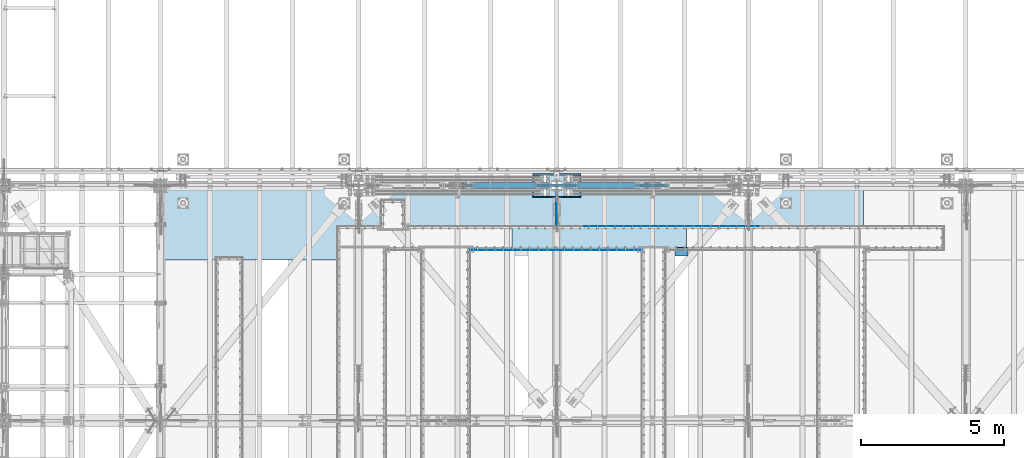
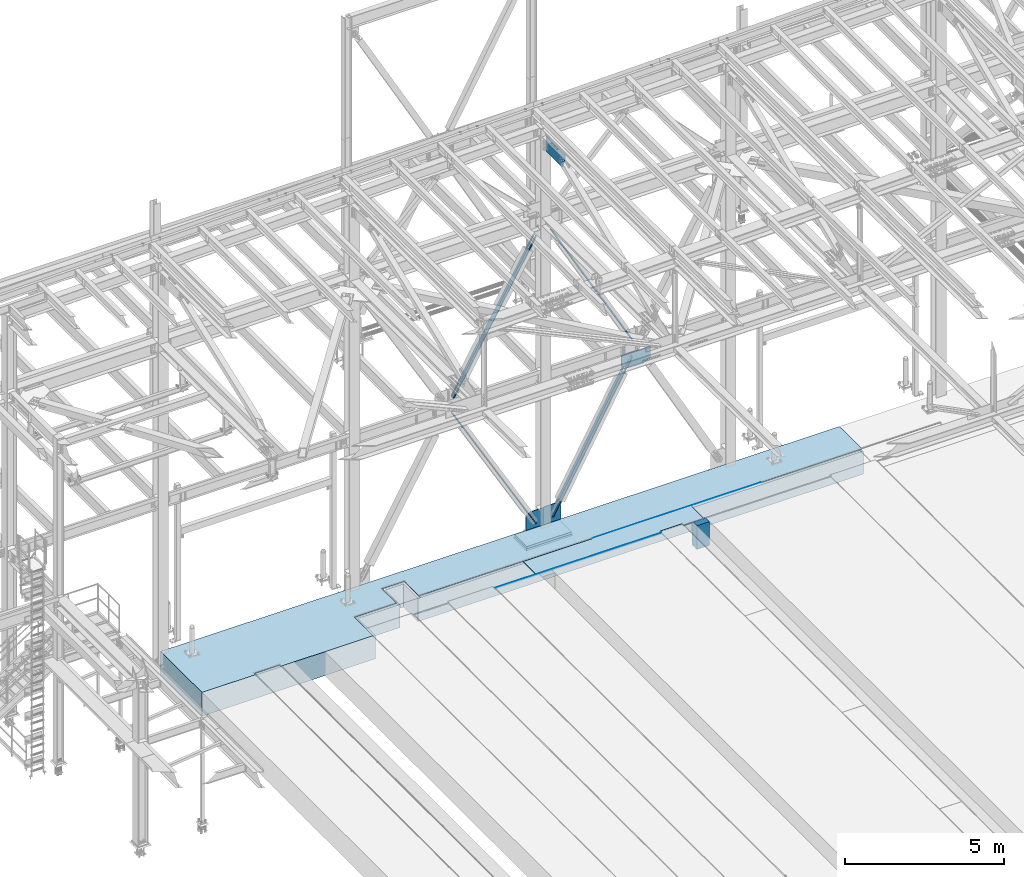
# One storey, part 2992 of 3843: 13 plates, 2 slabs, 13 elements without a shape of their own.
"""IFC2X3 building model written with IfcOpenShell, lengths in millimetres."""

from ifc_helpers import new_model, si_unit, frame, origin_with_axes, place, context, subcontext, project, spatial, faceted_brep, material, type_object, element, aggregate, save


model = new_model("IFC2X3")

# Units and contexts
model_context = context("Model", 3, precision=1e-05, world=origin_with_axes())
body_context = subcontext(model_context, "Body", "Model", "MODEL_VIEW")
ifc_project = project(units=[si_unit("LENGTHUNIT", "METRE", prefix="MILLI"), si_unit("AREAUNIT", "SQUARE_METRE"), si_unit("VOLUMEUNIT", "CUBIC_METRE"), si_unit("MASSUNIT", "GRAM", prefix="KILO"), si_unit("TIMEUNIT", "SECOND"), si_unit("PLANEANGLEUNIT", "RADIAN"), si_unit("SOLIDANGLEUNIT", "STERADIAN"), si_unit("THERMODYNAMICTEMPERATUREUNIT", "DEGREE_CELSIUS"), si_unit("LUMINOUSINTENSITYUNIT", "LUMEN")], contexts=[model_context])

# Site, building, storey
site_placement = place(None, origin_with_axes())
site = spatial("IfcSite", under=ifc_project, at=site_placement, CompositionType="ELEMENT")
building_placement = place(site_placement, origin_with_axes())
building = spatial("IfcBuilding", under=site, at=building_placement, Name="Undefined", CompositionType="ELEMENT")
storey_placement = place(building_placement, origin_with_axes())
storey = spatial("IfcBuildingStorey", under=building, at=storey_placement, Name="Undefined", CompositionType="ELEMENT", Elevation=0.0)

# Assembly, plate
assembly_1_placement = place(storey_placement, origin_with_axes())
assembly_1 = element("IfcElementAssembly", 1, at=assembly_1_placement, inside=storey, Name="EMBED_ANGLE", AssemblyPlace="NOTDEFINED", PredefinedType="RIGID_FRAME")
ifc_material_1 = material(Name="STEEL/A36")
plate_type_1 = type_object("IfcPlateType", PredefinedType="NOTDEFINED")
plate_1_placement = place(assembly_1_placement, frame((52883.562, 89966.6723125, 30480.0000003815), z_axis=(1.0, 0.0, 0.0), x_axis=(0.0, 0.0, -1.0)))
plate_1 = element("IfcPlate", 2, at=plate_1_placement, type_object=plate_type_1, material=ifc_material_1, Name="PLATE", context=body_context, shape_type="Brep", body=[
    faceted_brep([(0.0, -6.34999999999854, 12.6999998092651), (7.27595761418343e-12, 6.3499999046162, 0.0), (25.3999999999942, 6.34999999994034, 2.91038304567337e-11), (25.3999996185303, -1.58750000000873, 7.93749999998545), (20.6374996185259, -6.34999999993306, 12.7000361935643), (25.3999996185303, 6.35000000000582, 6032.56336035329), (25.3999996185194, -1.58750000000873, 6024.56327201604), (20.6374996185186, -6.35000000000582, 6019.80082138476), (3.80663550458848e-07, -6.35000000000582, 6019.80082138476), (3.81471181754023e-07, 6.35000000000582, 6032.56336035157)], [[[0, 1, 2, 3, 4]], [[3, 2, 5, 6]], [[4, 3, 6, 7]], [[0, 4, 7, 8]], [[1, 0, 8, 9]], [[2, 1, 9, 5]], [[8, 7, 6, 5, 9]]]),
])
aggregate(assembly_1, [plate_1])

assembly_2_placement = place(storey_placement, origin_with_axes())
assembly_2 = element("IfcElementAssembly", 3, at=assembly_2_placement, inside=storey, Name="EMBED_ANGLE", AssemblyPlace="NOTDEFINED", PredefinedType="RIGID_FRAME")
plate_2_placement = place(assembly_2_placement, frame((56903.1117470957, 90792.1730468558, 30480.0000003815), z_axis=(1.0, 0.0, 0.0), x_axis=(0.0, 0.0, -1.0)))
plate_2 = element("IfcPlate", 4, at=plate_2_placement, type_object=plate_type_1, material=ifc_material_1, Name="PLATE", context=body_context, shape_type="Brep", body=[
    faceted_brep([(25.3999986084054, 1.58750333315402, 6095.99959179856), (25.3999996185921, 1.58750000000146, 7.27595761418343e-11), (20.6374996185295, 6.35000000000218, -7.27595761418343e-12), (20.6374984169197, 6.35000001081789, 6095.99959179822), (0.0, -6.3499999046162, 0.0), (3.81471181754023e-07, -6.3499999891792, 6095.99959179686), (3.81471181754023e-07, 6.35000001081789, 6095.99959179683), (7.27595761418343e-12, 6.3499999046162, 0.0), (25.3999996185303, -6.34999999999491, 2.91038304567337e-11), (25.3999996185303, -6.3499999891792, 6095.99959179857)], [[[0, 1, 2, 3]], [[4, 5, 6, 7]], [[8, 9, 5, 4]], [[6, 5, 9, 0, 3]], [[7, 6, 3, 2]], [[8, 4, 7, 2, 1]], [[9, 8, 1, 0]]]),
])
aggregate(assembly_2, [plate_2])

assembly_3_placement = place(storey_placement, origin_with_axes())
assembly_3 = element("IfcElementAssembly", 5, at=assembly_3_placement, inside=storey, Name="PLATE", AssemblyPlace="NOTDEFINED", PredefinedType="RIGID_FRAME")
ifc_material_2 = material(Name="STEEL/A572-50")
plate_type_2 = type_object("IfcPlateType", PredefinedType="NOTDEFINED")
plate_3_placement = place(assembly_3_placement, frame((54372.6366220082, 90779.4730010014, 30467.3), z_axis=(1.0, 0.0, 0.0), x_axis=(0.0, -1.0, 0.0)))
plate_3 = element("IfcPlate", 6, at=plate_3_placement, type_object=plate_type_2, material=ifc_material_2, Name="PLATE", context=body_context, shape_type="Brep", body=[
    faceted_brep([(800.099781912155, -12.7000000000007, 4546.63359469063), (800.099781912155, 12.7000000000007, 4546.63359469063), (708.02026605772, 12.7000000000007, 4546.63359476539), (708.02026605772, -12.7000000000007, 4546.63359476539), (708.029934543127, 12.7000000000007, 5353.08063709154), (708.029934543127, -12.7000000000007, 5353.08063709154), (800.099743256913, -12.7000000000007, 5353.08063699721), (800.099743256913, 12.7000000000007, 5353.08063699721), (800.099999844999, -12.7000000000007, 3.34694050252438e-10), (0.0, -12.6999999999971, 0.0), (0.0, 12.6999999999971, 0.0), (800.099999844999, 12.7000000000007, 3.34694050252438e-10), (4.67670906800777e-06, -12.7000000000007, 6096.0), (4.67670906800777e-06, 12.7000000000007, 6096.0), (800.099707646717, -12.7000000000007, 6096.00000000033), (800.099707646717, 12.7000000000007, 6096.00000000033)], [[[0, 1, 2, 3]], [[3, 2, 4, 5]], [[6, 5, 4, 7]], [[8, 9, 10, 11]], [[9, 12, 13, 10]], [[12, 14, 15, 13]], [[15, 14, 6, 7]], [[2, 1, 11, 10, 13, 15, 7, 4]], [[8, 11, 1, 0]], [[14, 12, 9, 8, 0, 3, 5, 6]]]),
])
aggregate(assembly_3, [plate_3])

assembly_4_placement = place(storey_placement, origin_with_axes())
assembly_4 = element("IfcElementAssembly", 7, at=assembly_4_placement, inside=storey, Name="CB", AssemblyPlace="NOTDEFINED", PredefinedType="RIGID_FRAME")
plate_type_3 = type_object("IfcPlateType", PredefinedType="NOTDEFINED")
plate_4_placement = place(assembly_4_placement, frame((59116.8077083226, 92311.5375, 36501.1736877177), z_axis=(-0.488113231172773, 0.0, 0.872780312308931), x_axis=(0.0, -1.0, 0.0)))
plate_4 = element("IfcPlate", 8, at=plate_4_placement, type_object=plate_type_3, material=ifc_material_1, Name="CB", context=body_context, shape_type="Brep", body=[
    faceted_brep([(0.0, -12.7000000001135, 65.0875015259007), (0.0, -12.699999985547, 5868.19609691995), (0.0, 12.7000000144762, 5868.19609691988), (0.0, 12.6999999999025, 65.0875015259462), (4.95449104382715, -12.6999999854888, 5893.10400540797), (4.95449104382715, 12.7000000145345, 5893.10400540791), (19.063687826434, -12.6999999854306, 5914.21991061944), (19.063687826434, 12.7000000145927, 5914.21991061938), (40.1795930378867, -12.6999999854015, 5928.32910740207), (40.1795930378867, 12.7000000146218, 5928.32910740201), (65.0874999999942, -12.699999985387, 5933.28359844591), (65.0874999999942, 12.7000000146363, 5933.28359844584), (65.0874999999942, -12.6999999866966, 5401.86679924902), (65.0874999999942, 12.7000000133266, 5401.86679924896), (128.587499999994, -12.6999999866966, 5401.86679924902), (128.587499999994, 12.7000000133266, 5401.86679924896), (128.587498474109, -12.699999985387, 5933.28359844591), (128.587498474109, 12.7000000146363, 5933.28359844584), (153.495406962102, -12.6999999854015, 5928.32910740207), (153.495406962102, 12.7000000146218, 5928.32910740201), (174.611312173554, -12.6999999854306, 5914.21991061944), (174.611312173554, 12.7000000145927, 5914.21991061938), (188.720508956161, -12.6999999854888, 5893.10400540797), (188.720508956161, 12.7000000145345, 5893.10400540791), (193.674999999988, -12.699999985547, 5868.19609691995), (193.674999999988, 12.7000000144762, 5868.19609691988), (193.674999999988, -12.7000000001135, 65.0875015259007), (193.674999999988, 12.6999999999025, 65.0875015259462), (188.720508956161, -12.7000000000698, 40.1795930378939), (188.720508956161, 12.6999999999389, 40.1795930379376), (174.611312173554, -12.7000000000407, 19.0636878264304), (174.611312173554, 12.6999999999753, 19.0636878264741), (153.495406962102, -12.7000000000189, 4.9544910438035), (153.495406962102, 12.7000000000044, 4.95449104384716), (128.587499999994, -12.7000000000044, -2.00088834390044e-11), (128.587499999994, 12.7000000000116, 1.81898940354586e-11), (128.587499999994, -12.6999999980762, 531.416799185412), (128.587499999994, 12.7000000018015, 531.416799185514), (65.0874999999942, -12.6999999980762, 531.416799185412), (65.0874999999942, 12.7000000018015, 531.416799185514), (65.0875015258789, -12.7000000000044, -2.00088834390044e-11), (65.0875015258789, 12.7000000000116, 1.81898940354586e-11), (40.1795930378867, -12.7000000000189, 4.9544910438035), (40.1795930378867, 12.7000000000044, 4.95449104384716), (19.063687826434, -12.7000000000407, 19.0636878264304), (19.063687826434, 12.6999999999753, 19.0636878264741), (4.95449104382715, -12.7000000000698, 40.1795930378939), (4.95449104382715, 12.6999999999389, 40.1795930379376)], [[[0, 1, 2, 3]], [[1, 4, 5, 2]], [[4, 6, 7, 5]], [[6, 8, 9, 7]], [[8, 10, 11, 9]], [[10, 12, 13, 11]], [[12, 14, 15, 13]], [[14, 16, 17, 15]], [[16, 18, 19, 17]], [[18, 20, 21, 19]], [[20, 22, 23, 21]], [[22, 24, 25, 23]], [[24, 26, 27, 25]], [[26, 28, 29, 27]], [[28, 30, 31, 29]], [[30, 32, 33, 31]], [[32, 34, 35, 33]], [[34, 36, 37, 35]], [[36, 38, 39, 37]], [[38, 40, 41, 39]], [[40, 42, 43, 41]], [[42, 44, 45, 43]], [[44, 46, 47, 45]], [[46, 0, 3, 47]], [[5, 7, 9, 11, 13, 15, 17, 19, 21, 23, 25, 27, 29, 31, 33, 35, 37, 39, 41, 43, 45, 47, 3, 2]], [[46, 44, 42, 40, 38, 36, 34, 32, 30, 28, 26, 24, 22, 20, 18, 16, 14, 12, 10, 8, 6, 4, 1, 0]]]),
])
aggregate(assembly_4, [plate_4])

assembly_5_placement = place(storey_placement, origin_with_axes())
assembly_5 = element("IfcElementAssembly", 9, at=assembly_5_placement, inside=storey, Name="CB", AssemblyPlace="NOTDEFINED", PredefinedType="RIGID_FRAME")
plate_5_placement = place(assembly_5_placement, frame((52636.3743118029, 92117.8625, 36501.4806364627), z_axis=(0.500674758933455, 0.0, 0.865635480884955), x_axis=(0.0, 1.0, 0.0)))
plate_5 = element("IfcPlate", 10, at=plate_5_placement, type_object=plate_type_3, material=ifc_material_1, Name="CB", context=body_context, shape_type="Brep", body=[
    faceted_brep([(0.0, -12.7000000001135, 65.0875015259007), (0.0, -12.7000000139742, 5944.39609689274), (0.0, 12.6999999860418, 5944.3960968928), (0.0, 12.6999999999025, 65.0875015259462), (4.95449104382715, -12.7000000140251, 5969.30400538074), (4.95449104382715, 12.6999999859909, 5969.30400538081), (19.063687826434, -12.7000000140833, 5990.4199105922), (19.063687826434, 12.6999999859399, 5990.41991059228), (40.1795930378867, -12.7000000141197, 6004.52910737484), (40.1795930378867, 12.6999999859036, 6004.5291073749), (65.0874999999942, -12.700000014127, 6009.48359841867), (65.0874999999942, 12.6999999858963, 6009.48359841872), (65.0874999999942, -12.7000000128755, 5478.06679922428), (65.0874999999942, 12.6999999871477, 5478.06679922433), (128.587499999994, -12.7000000128755, 5478.06679922428), (128.587499999994, 12.6999999871477, 5478.06679922433), (128.587498474109, -12.700000014127, 6009.48359841867), (128.587498474109, 12.6999999858963, 6009.48359841872), (153.495406962102, -12.7000000141197, 6004.52910737484), (153.495406962102, 12.6999999859036, 6004.5291073749), (174.611312173554, -12.7000000140833, 5990.4199105922), (174.611312173554, 12.6999999859399, 5990.41991059228), (188.720508956161, -12.7000000140251, 5969.30400538074), (188.720508956161, 12.6999999859909, 5969.30400538081), (193.674999999988, -12.7000000139742, 5944.39609689274), (193.674999999988, 12.6999999860418, 5944.3960968928), (193.674999999988, -12.7000000001135, 65.0875015259007), (193.674999999988, 12.6999999999025, 65.0875015259462), (188.720508956161, -12.7000000000698, 40.1795930378939), (188.720508956161, 12.6999999999389, 40.1795930379376), (174.611312173554, -12.7000000000407, 19.0636878264304), (174.611312173554, 12.6999999999753, 19.0636878264741), (153.495406962102, -12.7000000000189, 4.9544910438035), (153.495406962102, 12.7000000000044, 4.95449104384716), (128.587499999994, -12.7000000000044, -2.00088834390044e-11), (128.587499999994, 12.7000000000116, 1.81898940354586e-11), (128.587499999994, -12.6999999980762, 531.416799185412), (128.587499999994, 12.7000000018015, 531.416799185514), (65.0874999999942, -12.6999999980762, 531.416799185412), (65.0874999999942, 12.7000000018015, 531.416799185514), (65.0875015258789, -12.7000000000044, -2.00088834390044e-11), (65.0875015258789, 12.7000000000116, 1.81898940354586e-11), (40.1795930378867, -12.7000000000189, 4.9544910438035), (40.1795930378867, 12.7000000000044, 4.95449104384716), (19.063687826434, -12.7000000000407, 19.0636878264304), (19.063687826434, 12.6999999999753, 19.0636878264741), (4.95449104382715, -12.7000000000698, 40.1795930378939), (4.95449104382715, 12.6999999999389, 40.1795930379376)], [[[0, 1, 2, 3]], [[1, 4, 5, 2]], [[4, 6, 7, 5]], [[6, 8, 9, 7]], [[8, 10, 11, 9]], [[10, 12, 13, 11]], [[12, 14, 15, 13]], [[14, 16, 17, 15]], [[16, 18, 19, 17]], [[18, 20, 21, 19]], [[20, 22, 23, 21]], [[22, 24, 25, 23]], [[24, 26, 27, 25]], [[26, 28, 29, 27]], [[28, 30, 31, 29]], [[30, 32, 33, 31]], [[32, 34, 35, 33]], [[34, 36, 37, 35]], [[36, 38, 39, 37]], [[38, 40, 41, 39]], [[40, 42, 43, 41]], [[42, 44, 45, 43]], [[44, 46, 47, 45]], [[46, 0, 3, 47]], [[5, 7, 9, 11, 13, 15, 17, 19, 21, 23, 25, 27, 29, 31, 33, 35, 37, 39, 41, 43, 45, 47, 3, 2]], [[46, 44, 42, 40, 38, 36, 34, 32, 30, 28, 26, 24, 22, 20, 18, 16, 14, 12, 10, 8, 6, 4, 1, 0]]]),
])
aggregate(assembly_5, [plate_5])

assembly_6_placement = place(storey_placement, origin_with_axes())
assembly_6 = element("IfcElementAssembly", 11, at=assembly_6_placement, inside=storey, Name="CB", AssemblyPlace="NOTDEFINED", PredefinedType="RIGID_FRAME")
plate_type_4 = type_object("IfcPlateType", PredefinedType="NOTDEFINED")
plate_6_placement = place(assembly_6_placement, frame((56233.1687753783, 92101.9875, 30695.6958993129), z_axis=(0.484532240013288, 0.0, 0.874773404023982), x_axis=(0.0, 1.0, 0.0)))
plate_6 = element("IfcPlate", 12, at=plate_6_placement, type_object=plate_type_4, material=ifc_material_1, Name="CB", context=body_context, shape_type="Brep", body=[
    faceted_brep([(0.0, -15.8749999998581, 77.7874984741429), (0.0, -15.8750000088621, 5849.62723327328), (0.0, 15.8749999911088, 5849.62723327333), (0.0, 15.8750000001437, 77.7874984740847), (5.92122074862709, -15.8750000089058, 5879.39522018442), (5.92122074862709, 15.8749999910651, 5879.39522018447), (22.7834308115271, -15.8750000089422, 5904.63130093583), (22.7834308115271, 15.874999991036, 5904.63130093587), (48.0195115629467, -15.875000008964, 5921.49351099871), (48.0195115629467, 15.8749999910069, 5921.49351099876), (77.7874999999913, -15.8750000089785, 5927.41473174734), (77.7874999999913, 15.8749999909924, 5927.41473174738), (77.7874999999913, -15.8750000080327, 5303.6823658783), (77.7874999999913, 15.8749999919382, 5303.68236587834), (147.637499999997, -15.8750000080327, 5303.6823658783), (147.637499999997, 15.8749999919382, 5303.68236587834), (147.637501525867, -15.8750000089785, 5927.41473174734), (147.637501525867, 15.8749999909924, 5927.41473174738), (177.405488437042, -15.875000008964, 5921.49351099871), (177.405488437042, 15.8749999910069, 5921.49351099876), (202.641569188461, -15.8750000089422, 5904.63130093583), (202.641569188461, 15.874999991036, 5904.63130093587), (219.503779251361, -15.8750000089058, 5879.39522018442), (219.503779251361, 15.8749999910651, 5879.39522018447), (225.424999999988, -15.8750000088621, 5849.62723327328), (225.424999999988, 15.8749999911088, 5849.62723327333), (225.425000000003, -15.8749999998581, 77.7874984741429), (225.425000000003, 15.8750000001437, 77.7874984740847), (219.503779251376, -15.8749999999109, 48.0195115629685), (219.503779251376, 15.8750000000891, 48.0195115629249), (202.641569188469, -15.8749999999582, 22.7834308115562), (202.641569188469, 15.87500000004, 22.7834308115052), (177.405488437056, -15.8749999999891, 5.92122074864892), (177.405488437056, 15.8750000000109, 5.92122074859071), (147.637500000004, -15.8749999999982, 2.18278728425503e-11), (147.637500000004, 15.8750000000018, -2.91038304567337e-11), (147.637500000004, -15.8749999988613, 623.732365867771), (147.637500000004, 15.8750000011369, 623.732365867712), (77.7874999999985, -15.8749999988613, 623.732365867771), (77.7874999999985, 15.8750000011369, 623.732365867712), (77.7874984741211, -15.8749999999982, 2.18278728425503e-11), (77.7874984741211, 15.8750000000018, -2.91038304567337e-11), (48.0195115629467, -15.8749999999891, 5.92122074864892), (48.0195115629467, 15.8750000000109, 5.92122074859071), (22.7834308115343, -15.8749999999582, 22.7834308115562), (22.7834308115343, 15.87500000004, 22.7834308115052), (5.92122074862709, -15.8749999999109, 48.0195115629685), (5.92122074862709, 15.8750000000891, 48.0195115629249)], [[[0, 1, 2, 3]], [[1, 4, 5, 2]], [[4, 6, 7, 5]], [[6, 8, 9, 7]], [[8, 10, 11, 9]], [[10, 12, 13, 11]], [[12, 14, 15, 13]], [[14, 16, 17, 15]], [[16, 18, 19, 17]], [[18, 20, 21, 19]], [[20, 22, 23, 21]], [[22, 24, 25, 23]], [[24, 26, 27, 25]], [[26, 28, 29, 27]], [[28, 30, 31, 29]], [[30, 32, 33, 31]], [[32, 34, 35, 33]], [[34, 36, 37, 35]], [[36, 38, 39, 37]], [[38, 40, 41, 39]], [[40, 42, 43, 41]], [[42, 44, 45, 43]], [[44, 46, 47, 45]], [[46, 0, 3, 47]], [[5, 7, 9, 11, 13, 15, 17, 19, 21, 23, 25, 27, 29, 31, 33, 35, 37, 39, 41, 43, 45, 47, 3, 2]], [[46, 44, 42, 40, 38, 36, 34, 32, 30, 28, 26, 24, 22, 20, 18, 16, 14, 12, 10, 8, 6, 4, 1, 0]]]),
])
aggregate(assembly_6, [plate_6])

assembly_7_placement = place(storey_placement, origin_with_axes())
assembly_7 = element("IfcElementAssembly", 13, at=assembly_7_placement, inside=storey, Name="CB", AssemblyPlace="NOTDEFINED", PredefinedType="RIGID_FRAME")
plate_7_placement = place(assembly_7_placement, frame((55636.4181416141, 92327.4125, 30663.7551399682), z_axis=(-0.497020968229067, 0.0, 0.867738530399936), x_axis=(0.0, -1.0, 0.0)))
plate_7 = element("IfcPlate", 14, at=plate_7_placement, type_object=plate_type_4, material=ifc_material_1, Name="CB", context=body_context, shape_type="Brep", body=[
    faceted_brep([(0.0, -15.8749999998581, 77.7874984741429), (0.0, -15.8749999982392, 5951.22723325807), (0.0, 15.8750000016444, 5951.22723325812), (0.0, 15.8750000001437, 77.7874984740847), (5.92122074862709, -15.8749999982392, 5980.99522016923), (5.92122074862709, 15.8750000016516, 5980.99522016929), (22.7834308115271, -15.8749999982392, 6006.23130092065), (22.7834308115271, 15.8750000016589, 6006.2313009207), (48.0195115629467, -15.8749999982247, 6023.09351098355), (48.0195115629467, 15.8750000016735, 6023.0935109836), (77.7874999999913, -15.8749999982247, 6029.01473173218), (77.7874999999913, 15.8750000016662, 6029.01473173223), (77.7874999999913, -15.8749999983993, 5405.28236586473), (77.7874999999913, 15.8750000014988, 5405.28236586477), (147.637499999997, -15.8749999983993, 5405.28236586473), (147.637499999997, 15.8750000014988, 5405.28236586477), (147.637501525867, -15.8749999982247, 6029.01473173218), (147.637501525867, 15.8750000016662, 6029.01473173223), (177.405488437042, -15.8749999982247, 6023.09351098355), (177.405488437042, 15.8750000016735, 6023.0935109836), (202.641569188461, -15.8749999982392, 6006.23130092065), (202.641569188461, 15.8750000016589, 6006.2313009207), (219.503779251361, -15.8749999982392, 5980.99522016923), (219.503779251361, 15.8750000016516, 5980.99522016929), (225.424999999988, -15.8749999982392, 5951.22723325807), (225.424999999988, 15.8750000016444, 5951.22723325812), (225.425000000003, -15.8749999998581, 77.7874984741429), (225.425000000003, 15.8750000001437, 77.7874984740847), (219.503779251376, -15.8749999999109, 48.0195115629685), (219.503779251376, 15.8750000000891, 48.0195115629249), (202.641569188469, -15.8749999999582, 22.7834308115562), (202.641569188469, 15.87500000004, 22.7834308115052), (177.405488437056, -15.8749999999891, 5.92122074864892), (177.405488437056, 15.8750000000109, 5.92122074859071), (147.637500000004, -15.8749999999982, 2.18278728425503e-11), (147.637500000004, 15.8750000000018, -2.91038304567337e-11), (147.637500000004, -15.8749999988613, 623.732365867771), (147.637500000004, 15.8750000011369, 623.732365867712), (77.7874999999985, -15.8749999988613, 623.732365867771), (77.7874999999985, 15.8750000011369, 623.732365867712), (77.7874984741211, -15.8749999999982, 2.18278728425503e-11), (77.7874984741211, 15.8750000000018, -2.91038304567337e-11), (48.0195115629467, -15.8749999999891, 5.92122074864892), (48.0195115629467, 15.8750000000109, 5.92122074859071), (22.7834308115343, -15.8749999999582, 22.7834308115562), (22.7834308115343, 15.87500000004, 22.7834308115052), (5.92122074862709, -15.8749999999109, 48.0195115629685), (5.92122074862709, 15.8750000000891, 48.0195115629249)], [[[0, 1, 2, 3]], [[1, 4, 5, 2]], [[4, 6, 7, 5]], [[6, 8, 9, 7]], [[8, 10, 11, 9]], [[10, 12, 13, 11]], [[12, 14, 15, 13]], [[14, 16, 17, 15]], [[16, 18, 19, 17]], [[18, 20, 21, 19]], [[20, 22, 23, 21]], [[22, 24, 25, 23]], [[24, 26, 27, 25]], [[26, 28, 29, 27]], [[28, 30, 31, 29]], [[30, 32, 33, 31]], [[32, 34, 35, 33]], [[34, 36, 37, 35]], [[36, 38, 39, 37]], [[38, 40, 41, 39]], [[40, 42, 43, 41]], [[42, 44, 45, 43]], [[44, 46, 47, 45]], [[46, 0, 3, 47]], [[5, 7, 9, 11, 13, 15, 17, 19, 21, 23, 25, 27, 29, 31, 33, 35, 37, 39, 41, 43, 45, 47, 3, 2]], [[46, 44, 42, 40, 38, 36, 34, 32, 30, 28, 26, 24, 22, 20, 18, 16, 14, 12, 10, 8, 6, 4, 1, 0]]]),
])
aggregate(assembly_7, [plate_7])

assembly_8_placement = place(storey_placement, origin_with_axes())
assembly_8 = element("IfcElementAssembly", 15, at=assembly_8_placement, inside=storey, Name="BEAM", AssemblyPlace="NOTDEFINED", PredefinedType="RIGID_FRAME")
plate_type_5 = type_object("IfcPlateType", PredefinedType="NOTDEFINED")
plate_8_placement = place(assembly_8_placement, frame((58765.2297832198, 92214.7, 35552.1160354868), z_axis=(1.0, 0.0, 0.0), x_axis=(0.0, 0.0, 1.0)))
plate_8 = element("IfcPlate", 16, at=plate_8_placement, type_object=plate_type_5, material=ifc_material_2, Name="CB", context=body_context, shape_type="Brep", body=[
    faceted_brep([(0.0, -12.6999999999971, 0.0), (-143.810878184362, -12.6999999999971, 259.635832368069), (-143.810878184362, 12.6999999999971, 259.635832368069), (0.0, 12.6999999999971, 0.0), (-143.810878184362, -12.6999999999971, 524.720218895956), (-143.810878184362, 12.6999999999971, 524.720218895956), (-143.810878184362, -12.6999999999971, 799.785035339039), (-143.810878184362, 12.6999999999971, 799.785035339039), (-10.1855505036729, -12.6999999999971, 1041.53805481807), (-10.1855505036729, 12.6999999999971, 1041.53805481807), (417.458964513185, -12.6999999999971, 1041.53805481807), (417.458964513185, 12.6999999999971, 1041.53805481807), (417.458964513185, -12.6999999999971, 0.0), (417.458964513185, 12.6999999999971, 0.0)], [[[0, 1, 2, 3]], [[1, 4, 5, 2]], [[4, 6, 7, 5]], [[6, 8, 9, 7]], [[8, 10, 11, 9]], [[10, 12, 13, 11]], [[12, 0, 3, 13]], [[5, 7, 9, 11, 13, 3, 2]], [[12, 10, 8, 6, 4, 1, 0]]]),
])
aggregate(assembly_8, [plate_8])

# Assembly, plates
assembly_9_placement = place(storey_placement, origin_with_axes())
assembly_9 = element("IfcElementAssembly", 17, at=assembly_9_placement, inside=storey, Name="COLUMN", AssemblyPlace="NOTDEFINED", PredefinedType="RIGID_FRAME")
plate_type_6 = type_object("IfcPlateType", PredefinedType="NOTDEFINED")
plate_9_placement = place(assembly_9_placement, frame((55936.35625, 92214.7, 30149.8), z_axis=(0.0, 0.0, 1.0), x_axis=(1.0, 0.0, 0.0)))
plate_9 = element("IfcPlate", 18, at=plate_9_placement, type_object=plate_type_6, material=ifc_material_2, Name="CB", context=body_context, shape_type="Brep", body=[
    faceted_brep([(0.0, -12.6999999999971, 19.0499992370605), (0.0, -12.6999999999971, 989.410443847886), (0.0, 12.6999999999971, 989.410443847886), (0.0, 12.6999999999971, 19.0499992370605), (19.0499992370605, -12.6999999999971, 1008.46044308495), (19.0499992370605, 12.6999999999971, 1008.46044308495), (395.140771469036, -12.6999999999971, 1008.46044308495), (395.140771469036, 12.6999999999971, 1008.46044308495), (636.77505499556, -12.6999999999971, 874.620525087277), (636.77505499556, 12.6999999999971, 874.620525087277), (636.77505499556, -12.6999999999971, 0.0), (636.77505499556, 12.6999999999971, 0.0), (19.0500015258731, -12.6999999999971, -6.33008312433958e-10), (19.0500015258731, 12.6999999999971, 0.0)], [[[0, 1, 2, 3]], [[1, 4, 5, 2]], [[4, 6, 7, 5]], [[6, 8, 9, 7]], [[8, 10, 11, 9]], [[10, 12, 13, 11]], [[12, 0, 3, 13]], [[5, 7, 9, 11, 13, 3, 2]], [[12, 10, 8, 6, 4, 1, 0]]]),
])
plate_type_7 = type_object("IfcPlateType", PredefinedType="NOTDEFINED")
plate_10_placement = place(assembly_9_placement, frame((55925.24375, 92214.7, 30149.8), z_axis=(0.0, 0.0, 1.0), x_axis=(-1.0, 0.0, 0.0)))
plate_10 = element("IfcPlate", 19, at=plate_10_placement, type_object=plate_type_7, material=ifc_material_2, Name="CB", context=body_context, shape_type="Brep", body=[
    faceted_brep([(0.0, -12.6999999999971, 19.0499992370605), (0.0, -12.6999999999971, 965.537784629985), (0.0, 12.6999999999971, 965.537784629985), (0.0, 12.6999999999971, 19.0499992370605), (19.0499992370605, -12.6999999999971, 984.587783867046), (19.0499992370605, 12.6999999999971, 984.587783867046), (377.144391495181, -12.6999999999971, 984.587783867046), (377.144391495181, 12.6999999999971, 984.587783867046), (633.464965667743, -12.6999999999971, 837.773166917967), (633.464965667743, 12.6999999999971, 837.773166917967), (633.464965667743, -12.6999999999971, 0.0), (633.464965667743, 12.6999999999971, 0.0), (19.0500015258731, -12.6999999999971, -6.33008312433958e-10), (19.0500015258731, 12.6999999999971, 0.0)], [[[0, 1, 2, 3]], [[1, 4, 5, 2]], [[4, 6, 7, 5]], [[6, 8, 9, 7]], [[8, 10, 11, 9]], [[10, 12, 13, 11]], [[12, 0, 3, 13]], [[5, 7, 9, 11, 13, 3, 2]], [[12, 10, 8, 6, 4, 1, 0]]]),
])

# Assembly, plate
assembly_10_placement = place(storey_placement, origin_with_axes())
assembly_10 = element("IfcElementAssembly", 20, at=assembly_10_placement, inside=storey, Name="PLATE", AssemblyPlace="NOTDEFINED", PredefinedType="RIGID_FRAME")
plate_type_8 = type_object("IfcPlateType", PredefinedType="NOTDEFINED")
plate_11_placement = place(assembly_10_placement, frame((55930.8, 92036.9000000467, 45473.6159830395), z_axis=(0.0, 0.0, -1.0), x_axis=(0.0, -1.0, 0.0)))
plate_11 = element("IfcPlate", 21, at=plate_11_placement, type_object=plate_type_8, material=ifc_material_2, Name="PLATE", context=body_context, shape_type="Brep", body=[
    faceted_brep([(0.0, -7.9375, 0.0), (-1.2572854757309e-08, -7.9375, 576.149068458675), (-1.2572854757309e-08, 7.9375, 576.149068458675), (0.0, 7.9375, 0.0), (1027.4581708383, -7.9375, 576.149068481107), (1027.4581708383, 7.9375, 576.149068481107), (1196.51991388762, -7.9375, 165.054946609809), (1196.51991388762, 7.9375, 165.054946609809), (1196.51991388881, -7.9375, 8.70204530656338e-09), (1196.51991388881, 7.9375, 8.70204530656338e-09)], [[[0, 1, 2, 3]], [[1, 4, 5, 2]], [[4, 6, 7, 5]], [[6, 8, 9, 7]], [[8, 0, 3, 9]], [[5, 7, 9, 3, 2]], [[8, 6, 4, 1, 0]]]),
])
aggregate(assembly_10, [plate_11])

# Assembly, slab
assembly_11_placement = place(storey_placement, origin_with_axes())
assembly_11 = element("IfcElementAssembly", 22, at=assembly_11_placement, inside=storey, Name="SLAB", AssemblyPlace="NOTDEFINED", PredefinedType="REINFORCEMENT_UNIT")
ifc_material_3 = material(Name="CONCRETE/3000")
slab_type_1 = type_object("IfcSlabType", PredefinedType="NOTDEFINED")
slab_1_placement = place(assembly_11_placement, frame((60535.312, 90049.222703125, 30022.8), z_axis=(0.0, -1.0, 0.0), x_axis=(-1.0, 0.0, 0.0)))
slab_1 = element("IfcSlab", 23, at=slab_1_placement, type_object=slab_type_1, material=ifc_material_3, Name="SLAB", PredefinedType="FLOOR", context=body_context, shape_type="Brep", body=[
    faceted_brep([(457.199981689453, -431.800087170555, 76.2004286268348), (0.0, -431.800000759631, 76.2004286268348), (0.0, -431.800000000287, 0.0), (457.199981689453, -431.800086407595, 0.0), (457.199981689439, -457.200086407596, 76.200701442096), (0.0, -457.200000000001, 76.200701442096), (457.199981689453, 457.200000000001, 304.673004150391), (457.199981689453, 457.200000000001, 0.0), (0.0, 457.200000000001, 0.0), (0.0, 457.200000000001, 304.673004150391), (0.0, -457.200000000001, 304.673004150391), (457.199981689453, -457.200000000001, 304.673004150391)], [[[0, 1, 2, 3]], [[4, 5, 1, 0]], [[6, 7, 8, 9]], [[10, 11, 6, 9]], [[3, 7, 6, 11, 4, 0]], [[8, 7, 3, 2]], [[10, 9, 8, 2, 1, 5]], [[11, 10, 5, 4]]]),
])
aggregate(assembly_11, [slab_1])

assembly_12_placement = place(storey_placement, origin_with_axes())
assembly_12 = element("IfcElementAssembly", 24, at=assembly_12_placement, inside=storey, Name="SLAB", AssemblyPlace="NOTDEFINED", PredefinedType="REINFORCEMENT_UNIT")
slab_type_2 = type_object("IfcSlabType", PredefinedType="NOTDEFINED")
slab_2_placement = place(assembly_12_placement, frame((42062.4, 89614.3765625, 30022.8), z_axis=(0.0, 1.0, 0.0), x_axis=(1.0, 0.0, 0.0)))
slab_2 = element("IfcSlab", 25, at=slab_2_placement, type_object=slab_type_2, material=ifc_material_3, Name="SLAB", PredefinedType="FLOOR", context=body_context, shape_type="Brep", body=[
    faceted_brep([(1942.84600000063, -457.200000000001, -4.10364009439945e-09), (1942.84600000063, -441.324999925549, 9.06584318727255e-09), (1942.84600000065, -441.325000763827, 76.1984375087777), (1942.84600000065, -457.200000000001, 76.1984373341402), (2857.24600000069, -441.324999925531, -0.00156249094288796), (2857.24600000067, -441.325000763827, 76.1984375090542), (2857.24600000067, -457.200000000001, 76.1984373344167), (2857.24600000069, -457.200000000001, -6.03904481977224e-09), (0.0, -457.200000000001, 0.0), (3.40558472089469e-07, -457.200000000001, 2600.32348632812), (3.40558472089469e-07, 457.200000000001, 2600.32348632812), (0.0, 457.200000000001, 0.0), (6280.91162109375, 457.200000000001, -1.32713466882706e-08), (6280.91162109375, 457.200000000001, 1095.24645996094), (6280.91162109375, -431.800000000007, 1095.24645996094), (6280.91162109375, -431.800000000007, -1.32713466882706e-08), (6204.71162109413, -431.800000762069, 1171.44645996223), (6204.71162109164, -431.800000762069, -1.30385160446167e-08), (7804.91205761718, -431.799984758778, 1095.24645996094), (7804.91205761752, -431.799984758778, 1171.44645996096), (7728.71205746424, -431.79998552084, 1171.44645996102), (7804.91205761718, 457.200000000001, 1095.24645996094), (7804.91205761718, 457.200000000001, 2009.64642333984), (7804.91205761718, -431.800000000003, 2009.64642333984), (8465.31208203124, 457.200000000001, 2009.64642333984), (8465.31208203124, 457.200000000001, 1095.24645996094), (8465.31208203124, -431.799996698941, 1095.24645996094), (8465.31208203124, -431.799996698941, 2009.64642333984), (8541.4878785895, -431.799996318168, 2085.8468344648), (7728.71201941687, -431.800000380896, 2085.8464234179), (8541.48838745811, -431.799996318168, 1095.24645976894), (8541.48834831416, -431.799996318168, 1171.44689056234), (24607.01171875, 457.200000000001, 2600.32348632812), (24607.01171875, 457.200000000001, 1095.24645996094), (24607.01171875, -457.200000000001, 2600.32348632812), (24607.01171875, -431.79999997585, 1095.24645996094), (24607.012, -457.200000000001, 1171.44647920535), (24607.012, -431.800000356743, 1171.4464793325), (8541.48834844113, -457.200000000001, 1171.44689043518), (8541.48787871646, -457.200000000001, 2085.8468344648), (7728.71201954383, -457.200000000001, 2085.8464234179), (7728.7120575912, -457.200000000001, 1171.44645996102), (6204.71162134806, -457.200000000001, 1171.44645996223), (6204.71162134557, -457.200000000001, -1.31112756207585e-08)], [[[0, 1, 2, 3]], [[4, 5, 2, 1]], [[6, 5, 4, 7]], [[3, 2, 5, 6]], [[8, 9, 10, 11]], [[12, 13, 14, 15]], [[16, 17, 15, 14, 18, 19, 20]], [[13, 21, 18, 14]], [[18, 21, 22, 23, 19]], [[24, 25, 26, 27]], [[28, 29, 20, 19, 23, 27, 26, 30, 31]], [[22, 24, 27, 23]], [[21, 13, 12, 11, 10, 32, 33, 25, 24, 22]], [[9, 34, 32, 10]], [[35, 33, 32, 34, 36, 37]], [[26, 25, 33, 35, 30]], [[37, 31, 30, 35]], [[36, 38, 31, 37]], [[39, 28, 31, 38]], [[40, 29, 28, 39]], [[41, 20, 29, 40]], [[42, 16, 20, 41]], [[43, 17, 16, 42]], [[1, 0, 8, 11, 12, 15, 17, 43, 7, 4]], [[43, 42, 41, 40, 39, 38, 36, 34, 9, 8, 0, 3, 6, 7]]]),
])
aggregate(assembly_12, [slab_2])

# Assembly, plate
assembly_13_placement = place(storey_placement, origin_with_axes())
assembly_13 = element("IfcElementAssembly", 26, at=assembly_13_placement, inside=storey, Name="GROUT", AssemblyPlace="NOTDEFINED", PredefinedType="REINFORCEMENT_UNIT")
ifc_material_4 = material(Name="CONCRETE/Concrete_Undefined")
plate_type_9 = type_object("IfcPlateType", PredefinedType="NOTDEFINED")
plate_12_placement = place(assembly_13_placement, frame((55079.9, 92633.8, 30041.85), z_axis=(1.0, 0.0, 0.0), x_axis=(0.0, -1.0, 0.0)))
plate_12 = element("IfcPlate", 27, at=plate_12_placement, type_object=plate_type_9, material=ifc_material_4, Name="GROUT", context=body_context, shape_type="Brep", body=[
    faceted_brep([(38.1000000006898, -19.0499999997883, 1663.70000000022), (0.0, 19.0499999999993, 1701.80004882812), (0.0, 19.0500000000029, 0.0), (38.1000000006916, -19.0499999999811, 38.1000000006607), (800.099999999336, -19.0499999998101, 38.1000000006607), (838.200012207031, 19.0499999999993, 0.0), (838.200012207031, 19.0499999999993, 1701.80004882812), (800.099999999322, -19.0499999999956, 1663.70000000022)], [[[0, 1, 2, 3]], [[4, 5, 6, 7]], [[4, 7, 0, 3]], [[5, 4, 3, 2]], [[6, 5, 2, 1]], [[7, 6, 1, 0]]]),
])
aggregate(assembly_13, [plate_12])

# Plate
plate_type_10 = type_object("IfcPlateType", PredefinedType="NOTDEFINED")
plate_13_placement = place(assembly_9_placement, frame((55118.0, 92595.7, 30105.35), z_axis=(1.0, 0.0, 0.0), x_axis=(0.0, -1.0, 0.0)))
plate_13 = element("IfcPlate", 28, at=plate_13_placement, type_object=plate_type_10, material=ifc_material_2, Name="PLATE", context=body_context, shape_type="Brep", body=[
    faceted_brep([(0.0, -44.4500000000007, 0.0), (0.0, -44.4500000000007, 1625.59997558594), (0.0, 44.4500000000007, 1625.59997558594), (0.0, 44.4500000000007, 0.0), (762.0, -44.4500000000007, 1625.59997558594), (762.0, 44.4500000000007, 1625.59997558594), (762.0, -44.4500000000007, 0.0), (762.0, 44.4500000000007, 0.0)], [[[0, 1, 2, 3]], [[1, 4, 5, 2]], [[4, 6, 7, 5]], [[6, 0, 3, 7]], [[5, 7, 3, 2]], [[6, 4, 1, 0]]]),
])

aggregate(assembly_9, [plate_9, plate_10, plate_13])

save(model, "model.ifc")
